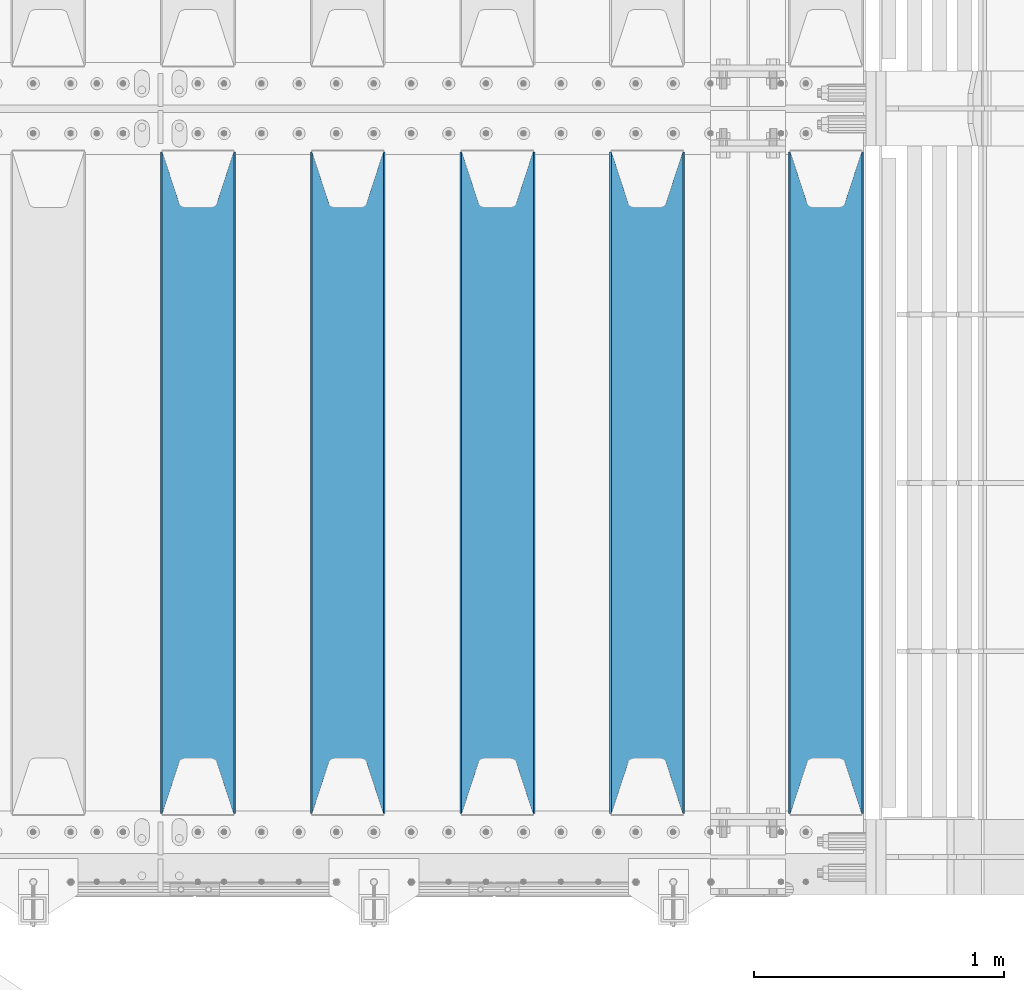
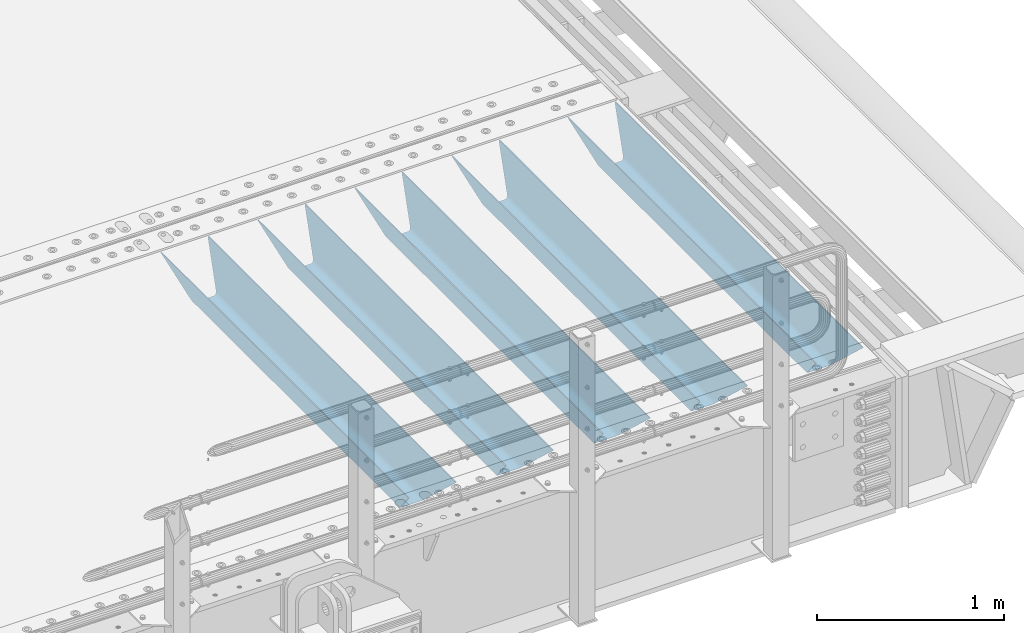
# One storey, part 108 of 240: 5 beams.
"""IFC2X3 building model written with IfcOpenShell, lengths in millimetres."""

from ifc_helpers import new_model, si_unit, frame, origin_with_axes, place, context, subcontext, project, spatial, faceted_brep, material, type_object, element, save


model = new_model("IFC2X3")

# Units and contexts
model_context = context("Model", 3, precision=1e-05, world=origin_with_axes())
body_context = subcontext(model_context, "Body", "Model", "MODEL_VIEW")
ifc_project = project(units=[si_unit("LENGTHUNIT", "METRE", prefix="MILLI"), si_unit("AREAUNIT", "SQUARE_METRE"), si_unit("VOLUMEUNIT", "CUBIC_METRE"), si_unit("MASSUNIT", "GRAM", prefix="KILO"), si_unit("TIMEUNIT", "SECOND"), si_unit("PLANEANGLEUNIT", "RADIAN"), si_unit("SOLIDANGLEUNIT", "STERADIAN"), si_unit("THERMODYNAMICTEMPERATUREUNIT", "DEGREE_CELSIUS"), si_unit("LUMINOUSINTENSITYUNIT", "LUMEN")], contexts=[model_context])

# Site, building, storey
site_placement = place(None, origin_with_axes())
site = spatial("IfcSite", under=ifc_project, at=site_placement, CompositionType="ELEMENT")
building_placement = place(site_placement, origin_with_axes())
building = spatial("IfcBuilding", under=site, at=building_placement, Name="Standard", CompositionType="ELEMENT")
storey_placement = place(building_placement, origin_with_axes())
storey = spatial("IfcBuildingStorey", under=building, at=storey_placement, Name="Undefined", CompositionType="ELEMENT", Elevation=0.0)

# Beams
ifc_material = material(Name="STEEL/S355N")
beam_type = type_object("IfcBeamType", PredefinedType="NOTDEFINED")
beam_1_placement = place(storey_placement, frame((56317.0, 24175.0, -115.0), z_axis=(0.0, 0.0, 1.0), x_axis=(0.0, 1.0, 0.0)))
element("IfcBeam", 1, at=beam_1_placement, inside=storey, type_object=beam_type, material=ifc_material, context=body_context, shape_type="Brep", body=[
    faceted_brep([(0.0, 150.0, 115.0), (0.0, 143.690000000002, 115.0), (2650.00000000297, 143.690000000002, 115.0), (2650.00000000297, 150.0, 115.0), (2650.00000000297, 142.059565218406, 110.000000003094), (2650.00000000297, 148.369565218403, 110.000000003094), (2441.90079219209, -80.1103600731149, -98.0992078077845), (2437.7588105432, -77.5672621345584, -102.241189456673), (2434.06523489747, -74.4080125315522, -105.934765102404), (2430.9108609509, -70.7102721255724, -109.089139048974), (2428.37322971128, -66.5649389910031, -111.626770288588), (2426.51472138055, -62.0739139532889, -113.485278619323), (2425.38102192092, -57.3475956567636, -114.618978078955), (2424.99999999987, -52.5021667386536, -115.0), (2424.99999999987, 52.5021667386536, -115.0), (2425.38102192092, 57.3475956567636, -114.618978078955), (2426.51472138055, 62.0739139532889, -113.485278619323), (2428.37322971128, 66.5649389910031, -111.626770288588), (2430.9108609509, 70.7102721255724, -109.089139048974), (2434.06523489747, 74.4080125315522, -105.934765102404), (2437.7588105432, 77.5672621345584, -102.241189456673), (2441.90079219209, 80.1103600731149, -98.0992078077846), (2446.38936140512, 81.9747917625791, -93.6106385947584), (2448.2494850041, 76.2713538057287, -91.7505149957729), (2444.62967112263, 74.76777986261, -95.3703288772456), (2441.28936334127, 72.7168944282894, -98.710636658607), (2438.31067330439, 70.1691124903809, -101.689326695487), (2435.76682334748, 67.1870637758839, -104.233176652398), (2433.72034654134, 63.8440531834931, -106.279653458539), (2432.22154950042, 60.2222587982324, -107.778450499454), (2431.30727574265, 56.4107117849126, -108.692724257221), (2430.99999999987, 52.5031078186876, -109.0), (2430.99999999987, -52.5031078186876, -109.0), (2431.30727574265, -56.4107117849126, -108.692724257221), (2432.22154950042, -60.2222587982324, -107.778450499454), (2433.72034654134, -63.8440531834931, -106.279653458539), (2435.76682334748, -67.1870637758839, -104.233176652398), (2438.31067330439, -70.1691124903809, -101.689326695487), (2441.28936334127, -72.7168944282894, -98.7106366586071), (2444.62967112263, -74.76777986261, -95.3703288772457), (2448.2494850041, -76.2713538057287, -91.7505149957729), (2650.00000000297, -142.059565218406, 110.000000003094), (2650.00000000297, -148.369565218403, 110.000000003094), (2446.38936140512, -81.9747917625791, -93.6106385947584), (2650.00000000297, -143.690000000002, 115.0), (2650.00000000297, -150.0, 115.0), (0.0, -143.690000000002, 115.0), (0.0, -150.0, 115.0), (0.0, -148.369565218258, 110.000000002667), (203.610638597427, -81.9747917625791, -93.6106385947584), (208.09920781045, -80.1103600731149, -98.0992078077845), (212.241189459342, -77.5672621345584, -102.241189456673), (215.93476510507, -74.4080125315522, -105.934765102404), (219.089139051641, -70.7102721255724, -109.089139048974), (221.626770291256, -66.5649389910031, -111.626770288588), (223.485278621989, -62.0739139532889, -113.485278619323), (224.618978081624, -57.3475956567636, -114.618978078955), (225.000000002663, -52.5021667386536, -115.0), (225.000000002663, 52.5021667386536, -115.0), (224.618978081624, 57.3475956567636, -114.618978078955), (223.485278621989, 62.0739139532889, -113.485278619323), (221.626770291256, 66.5649389910031, -111.626770288588), (219.089139051641, 70.7102721255724, -109.089139048974), (215.93476510507, 74.4080125315522, -105.934765102404), (212.241189459342, 77.5672621345584, -102.241189456673), (208.09920781045, 80.1103600731149, -98.0992078077846), (203.610638597427, 81.9747917625791, -93.6106385947584), (0.0, 148.369565218258, 110.000000002667), (0.0, 142.05956521826, 110.000000002667), (201.750514998439, 76.2713538057287, -91.7505149957729), (205.370328879908, 74.76777986261, -95.3703288772456), (208.710636661275, 72.7168944282894, -98.710636658607), (211.689326698153, 70.1691124903809, -101.689326695487), (214.233176655063, 67.1870637758839, -104.233176652398), (216.279653461206, 63.8440531834931, -106.279653458539), (217.778450502123, 60.2222587982324, -107.778450499454), (218.692724259887, 56.4107117849126, -108.692724257221), (219.000000002667, 52.5031078186876, -109.0), (219.000000002667, -52.5031078186876, -109.0), (218.692724259887, -56.4107117849126, -108.692724257221), (217.778450502123, -60.2222587982324, -107.778450499454), (216.279653461206, -63.8440531834931, -106.279653458539), (214.233176655063, -67.1870637758839, -104.233176652398), (211.689326698153, -70.1691124903809, -101.689326695487), (208.710636661275, -72.7168944282894, -98.7106366586071), (205.370328879915, -74.76777986261, -95.3703288772457), (201.750514998439, -76.2713538057287, -91.7505149957729), (0.0, -142.05956521826, 110.000000002667)], [[[0, 1, 2, 3]], [[3, 2, 4, 5]], [[6, 7, 8, 9, 10, 11, 12, 13, 14, 15, 16, 17, 18, 19, 20, 21, 22, 5, 4, 23, 24, 25, 26, 27, 28, 29, 30, 31, 32, 33, 34, 35, 36, 37, 38, 39, 40, 41, 42, 43]], [[44, 45, 42, 41]], [[46, 47, 45, 44]], [[43, 42, 45, 47, 48, 49]], [[6, 43, 49, 50]], [[7, 6, 50, 51]], [[8, 7, 51, 52]], [[9, 8, 52, 53]], [[10, 9, 53, 54]], [[11, 10, 54, 55]], [[12, 11, 55, 56]], [[13, 12, 56, 57]], [[14, 13, 57, 58]], [[15, 14, 58, 59]], [[16, 15, 59, 60]], [[17, 16, 60, 61]], [[18, 17, 61, 62]], [[19, 18, 62, 63]], [[20, 19, 63, 64]], [[21, 20, 64, 65]], [[22, 21, 65, 66]], [[0, 3, 5, 22, 66, 67]], [[1, 0, 67, 68]], [[23, 4, 2, 1, 68, 69]], [[24, 23, 69, 70]], [[25, 24, 70, 71]], [[26, 25, 71, 72]], [[27, 26, 72, 73]], [[28, 27, 73, 74]], [[29, 28, 74, 75]], [[30, 29, 75, 76]], [[31, 30, 76, 77]], [[32, 31, 77, 78]], [[33, 32, 78, 79]], [[34, 33, 79, 80]], [[35, 34, 80, 81]], [[36, 35, 81, 82]], [[37, 36, 82, 83]], [[38, 37, 83, 84]], [[39, 38, 84, 85]], [[40, 39, 85, 86]], [[46, 44, 41, 40, 86, 87]], [[47, 46, 87, 48]], [[86, 85, 84, 83, 82, 81, 80, 79, 78, 77, 76, 75, 74, 73, 72, 71, 70, 69, 68, 67, 66, 65, 64, 63, 62, 61, 60, 59, 58, 57, 56, 55, 54, 53, 52, 51, 50, 49, 48, 87]]]),
])
beam_2_placement = place(storey_placement, frame((55600.0, 24175.0, -115.0), z_axis=(0.0, 0.0, 1.0), x_axis=(0.0, 1.0, 0.0)))
element("IfcBeam", 2, at=beam_2_placement, inside=storey, type_object=beam_type, material=ifc_material, context=body_context, shape_type="Brep", body=[
    faceted_brep([(0.0, 150.0, 115.0), (0.0, 143.690000000002, 115.0), (2650.00000000297, 143.690000000002, 115.0), (2650.00000000297, 150.0, 115.0), (2650.00000000297, 142.059565218406, 110.000000003094), (2650.00000000297, 148.369565218403, 110.000000003094), (2441.90079219209, -80.1103600731149, -98.0992078077845), (2437.7588105432, -77.5672621345584, -102.241189456673), (2434.06523489747, -74.4080125315522, -105.934765102404), (2430.9108609509, -70.7102721255724, -109.089139048974), (2428.37322971128, -66.5649389910031, -111.626770288588), (2426.51472138055, -62.0739139532889, -113.485278619323), (2425.38102192092, -57.3475956567636, -114.618978078955), (2424.99999999987, -52.5021667386536, -115.0), (2424.99999999987, 52.5021667386536, -115.0), (2425.38102192092, 57.3475956567636, -114.618978078955), (2426.51472138055, 62.0739139532889, -113.485278619323), (2428.37322971128, 66.5649389910031, -111.626770288588), (2430.9108609509, 70.7102721255724, -109.089139048974), (2434.06523489747, 74.4080125315522, -105.934765102404), (2437.7588105432, 77.5672621345584, -102.241189456673), (2441.90079219209, 80.1103600731149, -98.0992078077846), (2446.38936140512, 81.9747917625791, -93.6106385947584), (2448.2494850041, 76.2713538057287, -91.7505149957729), (2444.62967112263, 74.76777986261, -95.3703288772456), (2441.28936334127, 72.7168944282894, -98.710636658607), (2438.31067330439, 70.1691124903809, -101.689326695487), (2435.76682334748, 67.1870637758839, -104.233176652398), (2433.72034654134, 63.8440531834931, -106.279653458539), (2432.22154950042, 60.2222587982324, -107.778450499454), (2431.30727574265, 56.4107117849126, -108.692724257221), (2430.99999999987, 52.5031078186876, -109.0), (2430.99999999987, -52.5031078186876, -109.0), (2431.30727574265, -56.4107117849126, -108.692724257221), (2432.22154950042, -60.2222587982324, -107.778450499454), (2433.72034654134, -63.8440531834931, -106.279653458539), (2435.76682334748, -67.1870637758839, -104.233176652398), (2438.31067330439, -70.1691124903809, -101.689326695487), (2441.28936334127, -72.7168944282894, -98.7106366586071), (2444.62967112263, -74.76777986261, -95.3703288772457), (2448.2494850041, -76.2713538057287, -91.7505149957729), (2650.00000000297, -142.059565218406, 110.000000003094), (2650.00000000297, -148.369565218403, 110.000000003094), (2446.38936140512, -81.9747917625791, -93.6106385947584), (2650.00000000297, -143.690000000002, 115.0), (2650.00000000297, -150.0, 115.0), (0.0, -143.690000000002, 115.0), (0.0, -150.0, 115.0), (0.0, -148.369565218258, 110.000000002667), (203.610638597427, -81.9747917625791, -93.6106385947584), (208.09920781045, -80.1103600731149, -98.0992078077845), (212.241189459342, -77.5672621345584, -102.241189456673), (215.93476510507, -74.4080125315522, -105.934765102404), (219.089139051641, -70.7102721255724, -109.089139048974), (221.626770291256, -66.5649389910031, -111.626770288588), (223.485278621989, -62.0739139532889, -113.485278619323), (224.618978081624, -57.3475956567636, -114.618978078955), (225.000000002663, -52.5021667386536, -115.0), (225.000000002663, 52.5021667386536, -115.0), (224.618978081624, 57.3475956567636, -114.618978078955), (223.485278621989, 62.0739139532889, -113.485278619323), (221.626770291256, 66.5649389910031, -111.626770288588), (219.089139051641, 70.7102721255724, -109.089139048974), (215.93476510507, 74.4080125315522, -105.934765102404), (212.241189459342, 77.5672621345584, -102.241189456673), (208.09920781045, 80.1103600731149, -98.0992078077846), (203.610638597427, 81.9747917625791, -93.6106385947584), (0.0, 148.369565218258, 110.000000002667), (0.0, 142.05956521826, 110.000000002667), (201.750514998439, 76.2713538057287, -91.7505149957729), (205.370328879908, 74.76777986261, -95.3703288772456), (208.710636661275, 72.7168944282894, -98.710636658607), (211.689326698153, 70.1691124903809, -101.689326695487), (214.233176655063, 67.1870637758839, -104.233176652398), (216.279653461206, 63.8440531834931, -106.279653458539), (217.778450502123, 60.2222587982324, -107.778450499454), (218.692724259887, 56.4107117849126, -108.692724257221), (219.000000002667, 52.5031078186876, -109.0), (219.000000002667, -52.5031078186876, -109.0), (218.692724259887, -56.4107117849126, -108.692724257221), (217.778450502123, -60.2222587982324, -107.778450499454), (216.279653461206, -63.8440531834931, -106.279653458539), (214.233176655063, -67.1870637758839, -104.233176652398), (211.689326698153, -70.1691124903809, -101.689326695487), (208.710636661275, -72.7168944282894, -98.7106366586071), (205.370328879915, -74.76777986261, -95.3703288772457), (201.750514998439, -76.2713538057287, -91.7505149957729), (0.0, -142.05956521826, 110.000000002667)], [[[0, 1, 2, 3]], [[3, 2, 4, 5]], [[6, 7, 8, 9, 10, 11, 12, 13, 14, 15, 16, 17, 18, 19, 20, 21, 22, 5, 4, 23, 24, 25, 26, 27, 28, 29, 30, 31, 32, 33, 34, 35, 36, 37, 38, 39, 40, 41, 42, 43]], [[44, 45, 42, 41]], [[46, 47, 45, 44]], [[43, 42, 45, 47, 48, 49]], [[6, 43, 49, 50]], [[7, 6, 50, 51]], [[8, 7, 51, 52]], [[9, 8, 52, 53]], [[10, 9, 53, 54]], [[11, 10, 54, 55]], [[12, 11, 55, 56]], [[13, 12, 56, 57]], [[14, 13, 57, 58]], [[15, 14, 58, 59]], [[16, 15, 59, 60]], [[17, 16, 60, 61]], [[18, 17, 61, 62]], [[19, 18, 62, 63]], [[20, 19, 63, 64]], [[21, 20, 64, 65]], [[22, 21, 65, 66]], [[0, 3, 5, 22, 66, 67]], [[1, 0, 67, 68]], [[23, 4, 2, 1, 68, 69]], [[24, 23, 69, 70]], [[25, 24, 70, 71]], [[26, 25, 71, 72]], [[27, 26, 72, 73]], [[28, 27, 73, 74]], [[29, 28, 74, 75]], [[30, 29, 75, 76]], [[31, 30, 76, 77]], [[32, 31, 77, 78]], [[33, 32, 78, 79]], [[34, 33, 79, 80]], [[35, 34, 80, 81]], [[36, 35, 81, 82]], [[37, 36, 82, 83]], [[38, 37, 83, 84]], [[39, 38, 84, 85]], [[40, 39, 85, 86]], [[46, 44, 41, 40, 86, 87]], [[47, 46, 87, 48]], [[86, 85, 84, 83, 82, 81, 80, 79, 78, 77, 76, 75, 74, 73, 72, 71, 70, 69, 68, 67, 66, 65, 64, 63, 62, 61, 60, 59, 58, 57, 56, 55, 54, 53, 52, 51, 50, 49, 48, 87]]]),
])
beam_3_placement = place(storey_placement, frame((55000.0, 24175.0, -115.0), z_axis=(0.0, 0.0, 1.0), x_axis=(0.0, 1.0, 0.0)))
element("IfcBeam", 3, at=beam_3_placement, inside=storey, type_object=beam_type, material=ifc_material, context=body_context, shape_type="Brep", body=[
    faceted_brep([(0.0, 150.0, 115.0), (0.0, 143.690000000002, 115.0), (2650.00000000297, 143.690000000002, 115.0), (2650.00000000297, 150.0, 115.0), (2650.00000000297, 142.059565218406, 110.000000003094), (2650.00000000297, 148.369565218403, 110.000000003094), (2441.90079219209, -80.1103600731149, -98.0992078077845), (2437.7588105432, -77.5672621345584, -102.241189456673), (2434.06523489747, -74.4080125315522, -105.934765102404), (2430.9108609509, -70.7102721255724, -109.089139048974), (2428.37322971128, -66.5649389910031, -111.626770288588), (2426.51472138055, -62.0739139532889, -113.485278619323), (2425.38102192092, -57.3475956567636, -114.618978078955), (2424.99999999987, -52.5021667386536, -115.0), (2424.99999999987, 52.5021667386536, -115.0), (2425.38102192092, 57.3475956567636, -114.618978078955), (2426.51472138055, 62.0739139532889, -113.485278619323), (2428.37322971128, 66.5649389910031, -111.626770288588), (2430.9108609509, 70.7102721255724, -109.089139048974), (2434.06523489747, 74.4080125315522, -105.934765102404), (2437.7588105432, 77.5672621345584, -102.241189456673), (2441.90079219209, 80.1103600731149, -98.0992078077846), (2446.38936140512, 81.9747917625791, -93.6106385947584), (2448.2494850041, 76.2713538057287, -91.7505149957729), (2444.62967112263, 74.76777986261, -95.3703288772456), (2441.28936334127, 72.7168944282894, -98.710636658607), (2438.31067330439, 70.1691124903809, -101.689326695487), (2435.76682334748, 67.1870637758839, -104.233176652398), (2433.72034654134, 63.8440531834931, -106.279653458539), (2432.22154950042, 60.2222587982324, -107.778450499454), (2431.30727574265, 56.4107117849126, -108.692724257221), (2430.99999999987, 52.5031078186876, -109.0), (2430.99999999987, -52.5031078186876, -109.0), (2431.30727574265, -56.4107117849126, -108.692724257221), (2432.22154950042, -60.2222587982324, -107.778450499454), (2433.72034654134, -63.8440531834931, -106.279653458539), (2435.76682334748, -67.1870637758839, -104.233176652398), (2438.31067330439, -70.1691124903809, -101.689326695487), (2441.28936334127, -72.7168944282894, -98.7106366586071), (2444.62967112263, -74.76777986261, -95.3703288772457), (2448.2494850041, -76.2713538057287, -91.7505149957729), (2650.00000000297, -142.059565218406, 110.000000003094), (2650.00000000297, -148.369565218403, 110.000000003094), (2446.38936140512, -81.9747917625791, -93.6106385947584), (2650.00000000297, -143.690000000002, 115.0), (2650.00000000297, -150.0, 115.0), (0.0, -143.690000000002, 115.0), (0.0, -150.0, 115.0), (0.0, -148.369565218258, 110.000000002667), (203.610638597427, -81.9747917625791, -93.6106385947584), (208.09920781045, -80.1103600731149, -98.0992078077845), (212.241189459342, -77.5672621345584, -102.241189456673), (215.93476510507, -74.4080125315522, -105.934765102404), (219.089139051641, -70.7102721255724, -109.089139048974), (221.626770291256, -66.5649389910031, -111.626770288588), (223.485278621989, -62.0739139532889, -113.485278619323), (224.618978081624, -57.3475956567636, -114.618978078955), (225.000000002663, -52.5021667386536, -115.0), (225.000000002663, 52.5021667386536, -115.0), (224.618978081624, 57.3475956567636, -114.618978078955), (223.485278621989, 62.0739139532889, -113.485278619323), (221.626770291256, 66.5649389910031, -111.626770288588), (219.089139051641, 70.7102721255724, -109.089139048974), (215.93476510507, 74.4080125315522, -105.934765102404), (212.241189459342, 77.5672621345584, -102.241189456673), (208.09920781045, 80.1103600731149, -98.0992078077846), (203.610638597427, 81.9747917625791, -93.6106385947584), (0.0, 148.369565218258, 110.000000002667), (0.0, 142.05956521826, 110.000000002667), (201.750514998439, 76.2713538057287, -91.7505149957729), (205.370328879908, 74.76777986261, -95.3703288772456), (208.710636661275, 72.7168944282894, -98.710636658607), (211.689326698153, 70.1691124903809, -101.689326695487), (214.233176655063, 67.1870637758839, -104.233176652398), (216.279653461206, 63.8440531834931, -106.279653458539), (217.778450502123, 60.2222587982324, -107.778450499454), (218.692724259887, 56.4107117849126, -108.692724257221), (219.000000002667, 52.5031078186876, -109.0), (219.000000002667, -52.5031078186876, -109.0), (218.692724259887, -56.4107117849126, -108.692724257221), (217.778450502123, -60.2222587982324, -107.778450499454), (216.279653461206, -63.8440531834931, -106.279653458539), (214.233176655063, -67.1870637758839, -104.233176652398), (211.689326698153, -70.1691124903809, -101.689326695487), (208.710636661275, -72.7168944282894, -98.7106366586071), (205.370328879915, -74.76777986261, -95.3703288772457), (201.750514998439, -76.2713538057287, -91.7505149957729), (0.0, -142.05956521826, 110.000000002667)], [[[0, 1, 2, 3]], [[3, 2, 4, 5]], [[6, 7, 8, 9, 10, 11, 12, 13, 14, 15, 16, 17, 18, 19, 20, 21, 22, 5, 4, 23, 24, 25, 26, 27, 28, 29, 30, 31, 32, 33, 34, 35, 36, 37, 38, 39, 40, 41, 42, 43]], [[44, 45, 42, 41]], [[46, 47, 45, 44]], [[43, 42, 45, 47, 48, 49]], [[6, 43, 49, 50]], [[7, 6, 50, 51]], [[8, 7, 51, 52]], [[9, 8, 52, 53]], [[10, 9, 53, 54]], [[11, 10, 54, 55]], [[12, 11, 55, 56]], [[13, 12, 56, 57]], [[14, 13, 57, 58]], [[15, 14, 58, 59]], [[16, 15, 59, 60]], [[17, 16, 60, 61]], [[18, 17, 61, 62]], [[19, 18, 62, 63]], [[20, 19, 63, 64]], [[21, 20, 64, 65]], [[22, 21, 65, 66]], [[0, 3, 5, 22, 66, 67]], [[1, 0, 67, 68]], [[23, 4, 2, 1, 68, 69]], [[24, 23, 69, 70]], [[25, 24, 70, 71]], [[26, 25, 71, 72]], [[27, 26, 72, 73]], [[28, 27, 73, 74]], [[29, 28, 74, 75]], [[30, 29, 75, 76]], [[31, 30, 76, 77]], [[32, 31, 77, 78]], [[33, 32, 78, 79]], [[34, 33, 79, 80]], [[35, 34, 80, 81]], [[36, 35, 81, 82]], [[37, 36, 82, 83]], [[38, 37, 83, 84]], [[39, 38, 84, 85]], [[40, 39, 85, 86]], [[46, 44, 41, 40, 86, 87]], [[47, 46, 87, 48]], [[86, 85, 84, 83, 82, 81, 80, 79, 78, 77, 76, 75, 74, 73, 72, 71, 70, 69, 68, 67, 66, 65, 64, 63, 62, 61, 60, 59, 58, 57, 56, 55, 54, 53, 52, 51, 50, 49, 48, 87]]]),
])
beam_4_placement = place(storey_placement, frame((54400.0, 24175.0, -115.0), z_axis=(0.0, 0.0, 1.0), x_axis=(0.0, 1.0, 0.0)))
element("IfcBeam", 4, at=beam_4_placement, inside=storey, type_object=beam_type, material=ifc_material, context=body_context, shape_type="Brep", body=[
    faceted_brep([(0.0, 150.0, 115.0), (0.0, 143.690000000002, 115.0), (2650.00000000297, 143.690000000002, 115.0), (2650.00000000297, 150.0, 115.0), (2650.00000000297, 142.059565218406, 110.000000003094), (2650.00000000297, 148.369565218403, 110.000000003094), (2441.90079219209, -80.1103600731149, -98.0992078077845), (2437.7588105432, -77.5672621345584, -102.241189456673), (2434.06523489747, -74.4080125315522, -105.934765102404), (2430.9108609509, -70.7102721255724, -109.089139048974), (2428.37322971128, -66.5649389910031, -111.626770288588), (2426.51472138055, -62.0739139532889, -113.485278619323), (2425.38102192092, -57.3475956567636, -114.618978078955), (2424.99999999987, -52.5021667386536, -115.0), (2424.99999999987, 52.5021667386536, -115.0), (2425.38102192092, 57.3475956567636, -114.618978078955), (2426.51472138055, 62.0739139532889, -113.485278619323), (2428.37322971128, 66.5649389910031, -111.626770288588), (2430.9108609509, 70.7102721255724, -109.089139048974), (2434.06523489747, 74.4080125315522, -105.934765102404), (2437.7588105432, 77.5672621345584, -102.241189456673), (2441.90079219209, 80.1103600731149, -98.0992078077846), (2446.38936140512, 81.9747917625791, -93.6106385947584), (2448.2494850041, 76.2713538057287, -91.7505149957729), (2444.62967112263, 74.76777986261, -95.3703288772456), (2441.28936334127, 72.7168944282894, -98.710636658607), (2438.31067330439, 70.1691124903809, -101.689326695487), (2435.76682334748, 67.1870637758839, -104.233176652398), (2433.72034654134, 63.8440531834931, -106.279653458539), (2432.22154950042, 60.2222587982324, -107.778450499454), (2431.30727574265, 56.4107117849126, -108.692724257221), (2430.99999999987, 52.5031078186876, -109.0), (2430.99999999987, -52.5031078186876, -109.0), (2431.30727574265, -56.4107117849126, -108.692724257221), (2432.22154950042, -60.2222587982324, -107.778450499454), (2433.72034654134, -63.8440531834931, -106.279653458539), (2435.76682334748, -67.1870637758839, -104.233176652398), (2438.31067330439, -70.1691124903809, -101.689326695487), (2441.28936334127, -72.7168944282894, -98.7106366586071), (2444.62967112263, -74.76777986261, -95.3703288772457), (2448.2494850041, -76.2713538057287, -91.7505149957729), (2650.00000000297, -142.059565218406, 110.000000003094), (2650.00000000297, -148.369565218403, 110.000000003094), (2446.38936140512, -81.9747917625791, -93.6106385947584), (2650.00000000297, -143.690000000002, 115.0), (2650.00000000297, -150.0, 115.0), (0.0, -143.690000000002, 115.0), (0.0, -150.0, 115.0), (0.0, -148.369565218258, 110.000000002667), (203.610638597427, -81.9747917625791, -93.6106385947584), (208.09920781045, -80.1103600731149, -98.0992078077845), (212.241189459342, -77.5672621345584, -102.241189456673), (215.93476510507, -74.4080125315522, -105.934765102404), (219.089139051641, -70.7102721255724, -109.089139048974), (221.626770291256, -66.5649389910031, -111.626770288588), (223.485278621989, -62.0739139532889, -113.485278619323), (224.618978081624, -57.3475956567636, -114.618978078955), (225.000000002663, -52.5021667386536, -115.0), (225.000000002663, 52.5021667386536, -115.0), (224.618978081624, 57.3475956567636, -114.618978078955), (223.485278621989, 62.0739139532889, -113.485278619323), (221.626770291256, 66.5649389910031, -111.626770288588), (219.089139051641, 70.7102721255724, -109.089139048974), (215.93476510507, 74.4080125315522, -105.934765102404), (212.241189459342, 77.5672621345584, -102.241189456673), (208.09920781045, 80.1103600731149, -98.0992078077846), (203.610638597427, 81.9747917625791, -93.6106385947584), (0.0, 148.369565218258, 110.000000002667), (0.0, 142.05956521826, 110.000000002667), (201.750514998439, 76.2713538057287, -91.7505149957729), (205.370328879908, 74.76777986261, -95.3703288772456), (208.710636661275, 72.7168944282894, -98.710636658607), (211.689326698153, 70.1691124903809, -101.689326695487), (214.233176655063, 67.1870637758839, -104.233176652398), (216.279653461206, 63.8440531834931, -106.279653458539), (217.778450502123, 60.2222587982324, -107.778450499454), (218.692724259887, 56.4107117849126, -108.692724257221), (219.000000002667, 52.5031078186876, -109.0), (219.000000002667, -52.5031078186876, -109.0), (218.692724259887, -56.4107117849126, -108.692724257221), (217.778450502123, -60.2222587982324, -107.778450499454), (216.279653461206, -63.8440531834931, -106.279653458539), (214.233176655063, -67.1870637758839, -104.233176652398), (211.689326698153, -70.1691124903809, -101.689326695487), (208.710636661275, -72.7168944282894, -98.7106366586071), (205.370328879915, -74.76777986261, -95.3703288772457), (201.750514998439, -76.2713538057287, -91.7505149957729), (0.0, -142.05956521826, 110.000000002667)], [[[0, 1, 2, 3]], [[3, 2, 4, 5]], [[6, 7, 8, 9, 10, 11, 12, 13, 14, 15, 16, 17, 18, 19, 20, 21, 22, 5, 4, 23, 24, 25, 26, 27, 28, 29, 30, 31, 32, 33, 34, 35, 36, 37, 38, 39, 40, 41, 42, 43]], [[44, 45, 42, 41]], [[46, 47, 45, 44]], [[43, 42, 45, 47, 48, 49]], [[6, 43, 49, 50]], [[7, 6, 50, 51]], [[8, 7, 51, 52]], [[9, 8, 52, 53]], [[10, 9, 53, 54]], [[11, 10, 54, 55]], [[12, 11, 55, 56]], [[13, 12, 56, 57]], [[14, 13, 57, 58]], [[15, 14, 58, 59]], [[16, 15, 59, 60]], [[17, 16, 60, 61]], [[18, 17, 61, 62]], [[19, 18, 62, 63]], [[20, 19, 63, 64]], [[21, 20, 64, 65]], [[22, 21, 65, 66]], [[0, 3, 5, 22, 66, 67]], [[1, 0, 67, 68]], [[23, 4, 2, 1, 68, 69]], [[24, 23, 69, 70]], [[25, 24, 70, 71]], [[26, 25, 71, 72]], [[27, 26, 72, 73]], [[28, 27, 73, 74]], [[29, 28, 74, 75]], [[30, 29, 75, 76]], [[31, 30, 76, 77]], [[32, 31, 77, 78]], [[33, 32, 78, 79]], [[34, 33, 79, 80]], [[35, 34, 80, 81]], [[36, 35, 81, 82]], [[37, 36, 82, 83]], [[38, 37, 83, 84]], [[39, 38, 84, 85]], [[40, 39, 85, 86]], [[46, 44, 41, 40, 86, 87]], [[47, 46, 87, 48]], [[86, 85, 84, 83, 82, 81, 80, 79, 78, 77, 76, 75, 74, 73, 72, 71, 70, 69, 68, 67, 66, 65, 64, 63, 62, 61, 60, 59, 58, 57, 56, 55, 54, 53, 52, 51, 50, 49, 48, 87]]]),
])
beam_5_placement = place(storey_placement, frame((53800.0, 24175.0, -115.0), z_axis=(0.0, 0.0, 1.0), x_axis=(0.0, 1.0, 0.0)))
element("IfcBeam", 5, at=beam_5_placement, inside=storey, type_object=beam_type, material=ifc_material, context=body_context, shape_type="Brep", body=[
    faceted_brep([(0.0, 150.0, 115.0), (0.0, 143.690000000002, 115.0), (2650.00000000297, 143.690000000002, 115.0), (2650.00000000297, 150.0, 115.0), (2650.00000000297, 142.059565218406, 110.000000003094), (2650.00000000297, 148.369565218403, 110.000000003094), (2441.90079219209, -80.1103600731149, -98.0992078077845), (2437.7588105432, -77.5672621345584, -102.241189456673), (2434.06523489747, -74.4080125315522, -105.934765102404), (2430.9108609509, -70.7102721255724, -109.089139048974), (2428.37322971128, -66.5649389910031, -111.626770288588), (2426.51472138055, -62.0739139532889, -113.485278619323), (2425.38102192092, -57.3475956567636, -114.618978078955), (2424.99999999987, -52.5021667386536, -115.0), (2424.99999999987, 52.5021667386536, -115.0), (2425.38102192092, 57.3475956567636, -114.618978078955), (2426.51472138055, 62.0739139532889, -113.485278619323), (2428.37322971128, 66.5649389910031, -111.626770288588), (2430.9108609509, 70.7102721255724, -109.089139048974), (2434.06523489747, 74.4080125315522, -105.934765102404), (2437.7588105432, 77.5672621345584, -102.241189456673), (2441.90079219209, 80.1103600731149, -98.0992078077846), (2446.38936140512, 81.9747917625791, -93.6106385947584), (2448.2494850041, 76.2713538057287, -91.7505149957729), (2444.62967112263, 74.76777986261, -95.3703288772456), (2441.28936334127, 72.7168944282894, -98.710636658607), (2438.31067330439, 70.1691124903809, -101.689326695487), (2435.76682334748, 67.1870637758839, -104.233176652398), (2433.72034654134, 63.8440531834931, -106.279653458539), (2432.22154950042, 60.2222587982324, -107.778450499454), (2431.30727574265, 56.4107117849126, -108.692724257221), (2430.99999999987, 52.5031078186876, -109.0), (2430.99999999987, -52.5031078186876, -109.0), (2431.30727574265, -56.4107117849126, -108.692724257221), (2432.22154950042, -60.2222587982324, -107.778450499454), (2433.72034654134, -63.8440531834931, -106.279653458539), (2435.76682334748, -67.1870637758839, -104.233176652398), (2438.31067330439, -70.1691124903809, -101.689326695487), (2441.28936334127, -72.7168944282894, -98.7106366586071), (2444.62967112263, -74.76777986261, -95.3703288772457), (2448.2494850041, -76.2713538057287, -91.7505149957729), (2650.00000000297, -142.059565218406, 110.000000003094), (2650.00000000297, -148.369565218403, 110.000000003094), (2446.38936140512, -81.9747917625791, -93.6106385947584), (2650.00000000297, -143.690000000002, 115.0), (2650.00000000297, -150.0, 115.0), (0.0, -143.690000000002, 115.0), (0.0, -150.0, 115.0), (0.0, -148.369565218258, 110.000000002667), (203.610638597427, -81.9747917625791, -93.6106385947584), (208.09920781045, -80.1103600731149, -98.0992078077845), (212.241189459342, -77.5672621345584, -102.241189456673), (215.93476510507, -74.4080125315522, -105.934765102404), (219.089139051641, -70.7102721255724, -109.089139048974), (221.626770291256, -66.5649389910031, -111.626770288588), (223.485278621989, -62.0739139532889, -113.485278619323), (224.618978081624, -57.3475956567636, -114.618978078955), (225.000000002663, -52.5021667386536, -115.0), (225.000000002663, 52.5021667386536, -115.0), (224.618978081624, 57.3475956567636, -114.618978078955), (223.485278621989, 62.0739139532889, -113.485278619323), (221.626770291256, 66.5649389910031, -111.626770288588), (219.089139051641, 70.7102721255724, -109.089139048974), (215.93476510507, 74.4080125315522, -105.934765102404), (212.241189459342, 77.5672621345584, -102.241189456673), (208.09920781045, 80.1103600731149, -98.0992078077846), (203.610638597427, 81.9747917625791, -93.6106385947584), (0.0, 148.369565218258, 110.000000002667), (0.0, 142.05956521826, 110.000000002667), (201.750514998439, 76.2713538057287, -91.7505149957729), (205.370328879908, 74.76777986261, -95.3703288772456), (208.710636661275, 72.7168944282894, -98.710636658607), (211.689326698153, 70.1691124903809, -101.689326695487), (214.233176655063, 67.1870637758839, -104.233176652398), (216.279653461206, 63.8440531834931, -106.279653458539), (217.778450502123, 60.2222587982324, -107.778450499454), (218.692724259887, 56.4107117849126, -108.692724257221), (219.000000002667, 52.5031078186876, -109.0), (219.000000002667, -52.5031078186876, -109.0), (218.692724259887, -56.4107117849126, -108.692724257221), (217.778450502123, -60.2222587982324, -107.778450499454), (216.279653461206, -63.8440531834931, -106.279653458539), (214.233176655063, -67.1870637758839, -104.233176652398), (211.689326698153, -70.1691124903809, -101.689326695487), (208.710636661275, -72.7168944282894, -98.7106366586071), (205.370328879915, -74.76777986261, -95.3703288772457), (201.750514998439, -76.2713538057287, -91.7505149957729), (0.0, -142.05956521826, 110.000000002667)], [[[0, 1, 2, 3]], [[3, 2, 4, 5]], [[6, 7, 8, 9, 10, 11, 12, 13, 14, 15, 16, 17, 18, 19, 20, 21, 22, 5, 4, 23, 24, 25, 26, 27, 28, 29, 30, 31, 32, 33, 34, 35, 36, 37, 38, 39, 40, 41, 42, 43]], [[44, 45, 42, 41]], [[46, 47, 45, 44]], [[43, 42, 45, 47, 48, 49]], [[6, 43, 49, 50]], [[7, 6, 50, 51]], [[8, 7, 51, 52]], [[9, 8, 52, 53]], [[10, 9, 53, 54]], [[11, 10, 54, 55]], [[12, 11, 55, 56]], [[13, 12, 56, 57]], [[14, 13, 57, 58]], [[15, 14, 58, 59]], [[16, 15, 59, 60]], [[17, 16, 60, 61]], [[18, 17, 61, 62]], [[19, 18, 62, 63]], [[20, 19, 63, 64]], [[21, 20, 64, 65]], [[22, 21, 65, 66]], [[0, 3, 5, 22, 66, 67]], [[1, 0, 67, 68]], [[23, 4, 2, 1, 68, 69]], [[24, 23, 69, 70]], [[25, 24, 70, 71]], [[26, 25, 71, 72]], [[27, 26, 72, 73]], [[28, 27, 73, 74]], [[29, 28, 74, 75]], [[30, 29, 75, 76]], [[31, 30, 76, 77]], [[32, 31, 77, 78]], [[33, 32, 78, 79]], [[34, 33, 79, 80]], [[35, 34, 80, 81]], [[36, 35, 81, 82]], [[37, 36, 82, 83]], [[38, 37, 83, 84]], [[39, 38, 84, 85]], [[40, 39, 85, 86]], [[46, 44, 41, 40, 86, 87]], [[47, 46, 87, 48]], [[86, 85, 84, 83, 82, 81, 80, 79, 78, 77, 76, 75, 74, 73, 72, 71, 70, 69, 68, 67, 66, 65, 64, 63, 62, 61, 60, 59, 58, 57, 56, 55, 54, 53, 52, 51, 50, 49, 48, 87]]]),
])

save(model, "model.ifc")
